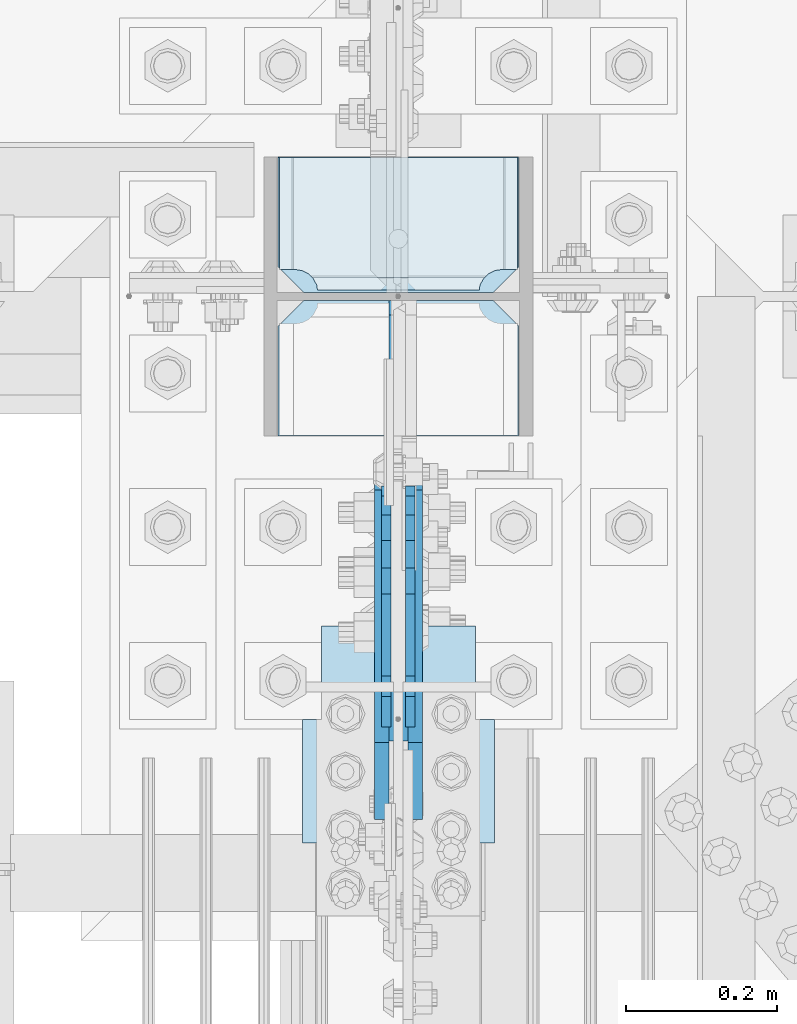
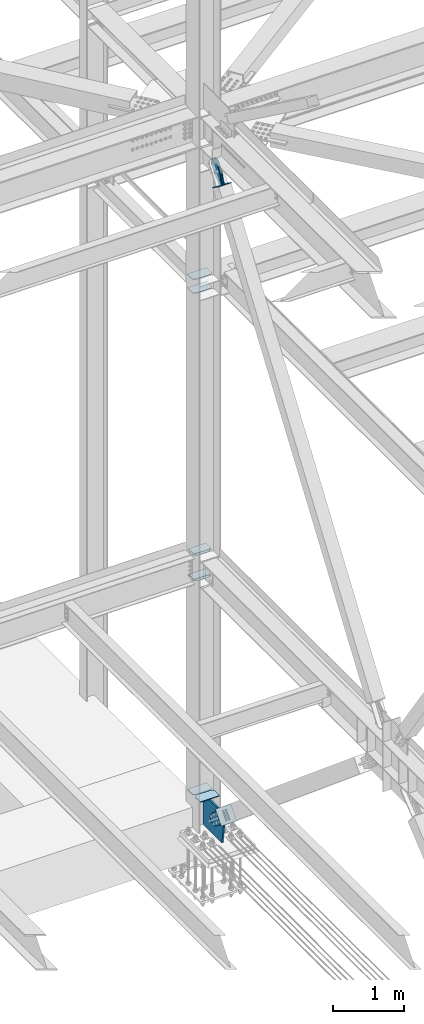
# One storey, part 3198 of 3843: 13 plates, 7 elements without a shape of their own.
"""IFC2X3 building model written with IfcOpenShell, lengths in millimetres."""

from ifc_helpers import new_model, si_unit, frame, origin_with_axes, place, context, subcontext, project, spatial, faceted_brep, material, type_object, element, aggregate, save


model = new_model("IFC2X3")

# Units and contexts
model_context = context("Model", 3, precision=1e-05, world=origin_with_axes())
body_context = subcontext(model_context, "Body", "Model", "MODEL_VIEW")
ifc_project = project(units=[si_unit("LENGTHUNIT", "METRE", prefix="MILLI"), si_unit("AREAUNIT", "SQUARE_METRE"), si_unit("VOLUMEUNIT", "CUBIC_METRE"), si_unit("MASSUNIT", "GRAM", prefix="KILO"), si_unit("TIMEUNIT", "SECOND"), si_unit("PLANEANGLEUNIT", "RADIAN"), si_unit("SOLIDANGLEUNIT", "STERADIAN"), si_unit("THERMODYNAMICTEMPERATUREUNIT", "DEGREE_CELSIUS"), si_unit("LUMINOUSINTENSITYUNIT", "LUMEN")], contexts=[model_context])

# Site, building, storey
site_placement = place(None, origin_with_axes())
site = spatial("IfcSite", under=ifc_project, at=site_placement, CompositionType="ELEMENT")
building_placement = place(site_placement, origin_with_axes())
building = spatial("IfcBuilding", under=site, at=building_placement, Name="Undefined", CompositionType="ELEMENT")
storey_placement = place(building_placement, origin_with_axes())
storey = spatial("IfcBuildingStorey", under=building, at=storey_placement, Name="Undefined", CompositionType="ELEMENT", Elevation=0.0)

# Assembly, plates
assembly_1_placement = place(storey_placement, origin_with_axes())
assembly_1 = element("IfcElementAssembly", 1, at=assembly_1_placement, inside=storey, Name="COLUMN", AssemblyPlace="NOTDEFINED", PredefinedType="RIGID_FRAME")
ifc_material_1 = material(Name="STEEL/A572-50")
plate_type_1 = type_object("IfcPlateType", PredefinedType="NOTDEFINED")
plate_1_placement = place(assembly_1_placement, frame((77171.55, 25799.25625, 39308.0875), z_axis=(-1.0, 0.0, 0.0), x_axis=(0.0, -1.0, 0.0)))
plate_1 = element("IfcPlate", 2, at=plate_1_placement, type_object=plate_type_1, material=ifc_material_1, Name="PLATE", context=body_context, shape_type="Brep", body=[
    faceted_brep([(0.0, -4.76249999999709, 0.0), (0.0, -4.76249999785796, 317.500000005042), (0.0, 4.76250000210712, 317.50000000505), (0.0, 4.76249999999709, 0.0), (144.462501525879, -4.76249999999709, 317.5), (144.462501525879, 4.76249999999709, 317.5), (177.800003051758, -4.76249999999709, 284.162498474121), (177.800003051758, 4.76249999999709, 284.162498474121), (177.800003051758, -4.76249999999709, 33.3375015258789), (177.800003051758, 4.76249999999709, 33.3375015258789), (144.462501525879, -4.76249999999709, 0.0), (144.462501525879, 4.76249999999709, 0.0)], [[[0, 1, 2, 3]], [[1, 4, 5, 2]], [[4, 6, 7, 5]], [[6, 8, 9, 7]], [[8, 10, 11, 9]], [[10, 0, 3, 11]], [[5, 7, 9, 11, 3, 2]], [[10, 8, 6, 4, 1, 0]]]),
])
plate_2_placement = place(assembly_1_placement, frame((77171.55, 25799.25625, 39546.2125), z_axis=(-1.0, 0.0, 0.0), x_axis=(0.0, -1.0, 0.0)))
plate_2 = element("IfcPlate", 3, at=plate_2_placement, type_object=plate_type_1, material=ifc_material_1, Name="PLATE", context=body_context, shape_type="Brep", body=[
    faceted_brep([(0.0, -4.76249999999709, 0.0), (0.0, -4.76249999785796, 317.500000005042), (0.0, 4.76250000210712, 317.50000000505), (0.0, 4.76249999999709, 0.0), (144.462501525879, -4.76249999999709, 317.5), (144.462501525879, 4.76249999999709, 317.5), (177.800003051758, -4.76249999999709, 284.162498474121), (177.800003051758, 4.76249999999709, 284.162498474121), (177.800003051758, -4.76249999999709, 33.3375015258789), (177.800003051758, 4.76249999999709, 33.3375015258789), (144.462501525879, -4.76249999999709, 0.0), (144.462501525879, 4.76249999999709, 0.0)], [[[0, 1, 2, 3]], [[1, 4, 5, 2]], [[4, 6, 7, 5]], [[6, 8, 9, 7]], [[8, 10, 11, 9]], [[10, 0, 3, 11]], [[5, 7, 9, 11, 3, 2]], [[10, 8, 6, 4, 1, 0]]]),
])
plate_type_2 = type_object("IfcPlateType", PredefinedType="NOTDEFINED")
plate_3_placement = place(assembly_1_placement, frame((77171.55, 25621.45625, 30670.8882042879), z_axis=(0.0, 1.0, 0.0), x_axis=(-1.0, 0.0, 0.0)))
plate_3 = element("IfcPlate", 4, at=plate_3_placement, type_object=plate_type_2, material=ifc_material_1, Name="CB_COL", context=body_context, shape_type="Brep", body=[
    faceted_brep([(0.0, -6.34999999999854, 33.3375015258789), (0.0, -6.34999999999854, 178.59375), (0.0, 6.34999999999854, 178.59375), (0.0, 6.34999999999854, 33.3375015258789), (317.499999999985, -6.34999999999854, 178.59375), (317.499999999985, 6.34999999999854, 178.59375), (317.499999999985, -6.34999999999854, 33.3375015258789), (317.499999999985, 6.34999999999854, 33.3375015258789), (284.162498474107, -6.34999999999854, 0.0), (284.162498474107, 6.34999999999854, 0.0), (33.3375015258789, -6.34999999999854, 0.0), (33.3375015258789, 6.34999999999854, 0.0)], [[[0, 1, 2, 3]], [[1, 4, 5, 2]], [[4, 6, 7, 5]], [[6, 8, 9, 7]], [[8, 10, 11, 9]], [[10, 0, 3, 11]], [[5, 7, 9, 11, 3, 2]], [[10, 8, 6, 4, 1, 0]]]),
])
plate_4_placement = place(assembly_1_placement, frame((77171.55, 25610.34375, 30670.8882042879), z_axis=(0.0, -1.0, 0.0), x_axis=(-1.0, 0.0, 0.0)))
plate_4 = element("IfcPlate", 5, at=plate_4_placement, type_object=plate_type_2, material=ifc_material_1, Name="CB_COL", context=body_context, shape_type="Brep", body=[
    faceted_brep([(0.0, -6.34999999999854, 33.3375015258789), (0.0, -6.34999999999854, 178.59375), (0.0, 6.34999999999854, 178.59375), (0.0, 6.34999999999854, 33.3375015258789), (317.499999999985, -6.34999999999854, 178.59375), (317.499999999985, 6.34999999999854, 178.59375), (317.499999999985, -6.34999999999854, 33.3375015258789), (317.499999999985, 6.34999999999854, 33.3375015258789), (284.162498474107, -6.34999999999854, 0.0), (284.162498474107, 6.34999999999854, 0.0), (33.3375015258789, -6.34999999999854, 0.0), (33.3375015258789, 6.34999999999854, 0.0)], [[[0, 1, 2, 3]], [[1, 4, 5, 2]], [[4, 6, 7, 5]], [[6, 8, 9, 7]], [[8, 10, 11, 9]], [[10, 0, 3, 11]], [[5, 7, 9, 11, 3, 2]], [[10, 8, 6, 4, 1, 0]]]),
])
plate_type_3 = type_object("IfcPlateType", PredefinedType="NOTDEFINED")
plate_5_placement = place(assembly_1_placement, frame((76852.4625, 25621.45625, 34358.2625), z_axis=(1.0, 0.0, 0.0), x_axis=(0.0, 1.0, 0.0)))
plate_5 = element("IfcPlate", 6, at=plate_5_placement, type_object=plate_type_3, material=ifc_material_1, Name="PLATE", context=body_context, shape_type="Brep", body=[
    faceted_brep([(17.7290728964945, 10.9213260443648, 272.460526505907), (19.6725343343096, 14.2874999999985, 274.403987943719), (19.6725343343096, 14.2874999999985, 46.2710120562842), (17.7290728964945, 10.9213260443648, 48.2144734940957), (9.32072521071677, -3.64235936715704, 52.4987406282016), (3.17474995173325, -14.2874999999985, 53.4721674798493), (3.17474995173325, -14.2874999999985, 267.202832520154), (9.32072521071314, -3.64235936715704, 268.176259371801), (30.1625003814697, 14.2874999999985, 301.002715665105), (30.1625003814697, -14.2874999999985, 317.500500047681), (177.799999999999, -14.2874999999985, 317.500500047681), (177.799999999999, 14.2874999999985, 301.002715665105), (177.799999999999, 14.2874999999985, 19.672284334898), (177.799999999999, -14.2874999999985, 3.17449995232164), (30.1625003814697, -14.2874999999985, 3.17449995232164), (30.1625003814697, 14.2874999999985, 19.672284334898), (9.32072521071314, -14.2874999999985, 268.176259371801), (17.7290728964945, -14.2874999999985, 272.460526505907), (24.401975401448, -14.2874999999985, 279.133429010864), (24.401975401448, 14.2874999999985, 279.133429010864), (28.6862425355503, -14.2874999999985, 287.541776696642), (28.6862425355503, 14.2874999999985, 287.541776696642), (30.1625003814697, -14.2874999999985, 296.862501907352), (30.1625003814697, 14.2874999999985, 296.862501907352), (30.1625003814697, -14.2874999999985, 23.8124980926514), (30.1625003814697, 14.2874999999985, 23.8124980926514), (28.6862425355503, -14.2874999999985, 33.1332233033609), (28.6862425355503, 14.2874999999985, 33.1332233033609), (24.401975401448, -14.2874999999985, 41.5415709891386), (24.401975401448, 14.2874999999985, 41.5415709891386), (17.7290728964945, -14.2874999999985, 48.2144734940957), (9.32072521071677, -14.2874999999985, 52.4987406282016)], [[[0, 1, 2, 3, 4, 5, 6, 7]], [[8, 9, 10, 11]], [[12, 13, 14, 15]], [[16, 7, 6]], [[16, 17, 0, 7]], [[17, 18, 19, 1, 0]], [[18, 20, 21, 19]], [[20, 22, 23, 21]], [[23, 22, 9, 8]], [[13, 12, 11, 10]], [[24, 25, 15, 14]], [[24, 26, 27, 25]], [[26, 28, 29, 27]], [[29, 28, 30, 3, 2]], [[30, 31, 4, 3]], [[31, 5, 4]], [[19, 21, 23, 8, 11, 12, 15, 25, 27, 29, 2, 1]], [[31, 30, 28, 26, 24, 14, 13, 10, 9, 22, 20, 18, 17, 16, 6, 5]]]),
])
plate_6_placement = place(assembly_1_placement, frame((76852.4625, 25621.45625, 34796.4125), z_axis=(1.0, 0.0, 0.0), x_axis=(0.0, 1.0, 0.0)))
plate_6 = element("IfcPlate", 7, at=plate_6_placement, type_object=plate_type_3, material=ifc_material_1, Name="PLATE", context=body_context, shape_type="Brep", body=[
    faceted_brep([(17.7290728964945, 10.9213260443648, 272.460526505907), (19.6725343343096, 14.2874999999985, 274.403987943719), (19.6725343343096, 14.2874999999985, 46.2710120562842), (17.7290728964945, 10.9213260443648, 48.2144734940957), (9.32072521071677, -3.64235936715704, 52.4987406282016), (3.17474995173325, -14.2874999999985, 53.4721674798493), (3.17474995173325, -14.2874999999985, 267.202832520154), (9.32072521071314, -3.64235936715704, 268.176259371801), (30.1625003814697, 14.2874999999985, 301.002715665105), (30.1625003814697, -14.2874999999985, 317.500500047681), (177.799999999999, -14.2874999999985, 317.500500047681), (177.799999999999, 14.2874999999985, 301.002715665105), (177.799999999999, 14.2874999999985, 19.672284334898), (177.799999999999, -14.2874999999985, 3.17449995232164), (30.1625003814697, -14.2874999999985, 3.17449995232164), (30.1625003814697, 14.2874999999985, 19.672284334898), (9.32072521071314, -14.2874999999985, 268.176259371801), (17.7290728964945, -14.2874999999985, 272.460526505907), (24.401975401448, -14.2874999999985, 279.133429010864), (24.401975401448, 14.2874999999985, 279.133429010864), (28.6862425355503, -14.2874999999985, 287.541776696642), (28.6862425355503, 14.2874999999985, 287.541776696642), (30.1625003814697, -14.2874999999985, 296.862501907352), (30.1625003814697, 14.2874999999985, 296.862501907352), (30.1625003814697, -14.2874999999985, 23.8124980926514), (30.1625003814697, 14.2874999999985, 23.8124980926514), (28.6862425355503, -14.2874999999985, 33.1332233033609), (28.6862425355503, 14.2874999999985, 33.1332233033609), (24.401975401448, -14.2874999999985, 41.5415709891386), (24.401975401448, 14.2874999999985, 41.5415709891386), (17.7290728964945, -14.2874999999985, 48.2144734940957), (9.32072521071677, -14.2874999999985, 52.4987406282016)], [[[0, 1, 2, 3, 4, 5, 6, 7]], [[8, 9, 10, 11]], [[12, 13, 14, 15]], [[16, 7, 6]], [[16, 17, 0, 7]], [[17, 18, 19, 1, 0]], [[18, 20, 21, 19]], [[20, 22, 23, 21]], [[23, 22, 9, 8]], [[13, 12, 11, 10]], [[24, 25, 15, 14]], [[24, 26, 27, 25]], [[26, 28, 29, 27]], [[29, 28, 30, 3, 2]], [[30, 31, 4, 3]], [[31, 5, 4]], [[19, 21, 23, 8, 11, 12, 15, 25, 27, 29, 2, 1]], [[31, 30, 28, 26, 24, 14, 13, 10, 9, 22, 20, 18, 17, 16, 6, 5]]]),
])

# Assembly, plate
assembly_2_placement = place(storey_placement, origin_with_axes())
assembly_2 = element("IfcElementAssembly", 8, at=assembly_2_placement, inside=storey, Name="Plate", AssemblyPlace="NOTDEFINED", PredefinedType="RIGID_FRAME")
ifc_material_2 = material(Name="STEEL/A36")
plate_type_4 = type_object("IfcPlateType", PredefinedType="NOTDEFINED")
plate_7_placement = place(assembly_2_placement, frame((77114.4, 25178.3977542612, 41391.6050428605), z_axis=(0.0, -0.820514786824001, 0.571625300877388), x_axis=(-1.0, 0.0, 0.0)))
plate_7 = element("IfcPlate", 9, at=plate_7_placement, type_object=plate_type_4, material=ifc_material_2, Name="Plate", context=body_context, shape_type="Brep", body=[
    faceted_brep([(0.0, -3.17499999999927, 0.0), (0.0, -3.17500000043947, 203.200000001736), (0.0, 3.1749999995518, 203.200000001743), (0.0, 3.17499999999927, 0.0), (203.200000000012, -3.17500000043947, 203.200000001736), (203.200000000012, 3.1749999995518, 203.200000001743), (203.199996948242, -3.17499999999927, 0.0), (203.199996948242, 3.17499999999927, 0.0)], [[[0, 1, 2, 3]], [[1, 4, 5, 2]], [[4, 6, 7, 5]], [[6, 0, 3, 7]], [[5, 7, 3, 2]], [[6, 4, 1, 0]]]),
])
aggregate(assembly_2, [plate_7])

assembly_3_placement = place(storey_placement, origin_with_axes())
assembly_3 = element("IfcElementAssembly", 10, at=assembly_3_placement, inside=storey, AssemblyPlace="NOTDEFINED", PredefinedType="RIGID_FRAME")
plate_type_5 = type_object("IfcPlateType", PredefinedType="NOTDEFINED")
plate_8_placement = place(assembly_3_placement, frame((76990.575, 25026.2019430032, 30733.5856528304), z_axis=(0.0, -0.641582193978324, -0.767054292974077), x_axis=(0.0, 0.767054292974076, -0.641582193978324)))
plate_8 = element("IfcPlate", 11, at=plate_8_placement, type_object=plate_type_5, material=ifc_material_2, context=body_context, shape_type="Brep", body=[
    faceted_brep([(0.0, -9.52500000000146, 0.0), (1.71894498635083e-09, -9.52499999999418, 158.39421297863), (1.71894498635083e-09, 9.52499999999418, 158.39421297863), (0.0, 9.52500000000146, 0.0), (69.8500000010408, -9.52499999999418, 158.394212979103), (69.8500000010408, 9.52499999999418, 158.394212979103), (171.450000002631, -9.52499999999418, 176.034606488582), (171.450000002631, 9.52499999999418, 176.034606488582), (390.129297671807, -9.52499999999418, 176.034606487716), (390.129297671807, 9.52499999999418, 176.034606487716), (427.187405137312, -9.52499999999418, 168.663290600991), (427.187405137312, 9.52499999999418, 168.663290600991), (458.60375167372, -9.52499999999418, 147.671558963724), (458.60375167372, 9.52499999999418, 147.671558963724), (479.59548331075, -9.52499999999418, 116.255212427161), (479.59548331075, 9.52499999999418, 116.255212427161), (486.966799197198, -9.52499999999418, 79.1971080138683), (486.966799197198, 9.52499999999418, 79.1971080138683), (479.595483310488, -9.52499999999418, 42.1390005483336), (479.595483310488, 9.52499999999418, 42.1390005483336), (458.603751673207, -9.52499999999418, 10.7226540119082), (458.603751673207, 9.52499999999418, 10.7226540119082), (427.18740513661, -9.52499999999418, -10.2690776251402), (427.18740513661, 9.52499999999418, -10.2690776251402), (390.129299195723, -9.52499999999418, -17.6403935115741), (390.129299195723, 9.52499999999418, -17.6403935115741), (171.450000001962, -9.52499999999418, -17.6403935107155), (171.450000001962, 9.52499999999418, -17.6403935107155), (69.8499999979995, -9.52499999999418, -4.00177668780088e-10), (69.8499999979995, 9.52499999999418, -4.00177668780088e-10)], [[[0, 1, 2, 3]], [[1, 4, 5, 2]], [[4, 6, 7, 5]], [[6, 8, 9, 7]], [[8, 10, 11, 9]], [[10, 12, 13, 11]], [[12, 14, 15, 13]], [[14, 16, 17, 15]], [[16, 18, 19, 17]], [[18, 20, 21, 19]], [[20, 22, 23, 21]], [[22, 24, 25, 23]], [[24, 26, 27, 25]], [[26, 28, 29, 27]], [[28, 0, 3, 29]], [[5, 7, 9, 11, 13, 15, 17, 19, 21, 23, 25, 27, 29, 3, 2]], [[28, 26, 24, 22, 20, 18, 16, 14, 12, 10, 8, 6, 4, 1, 0]]]),
])
aggregate(assembly_3, [plate_8])

assembly_4_placement = place(storey_placement, origin_with_axes())
assembly_4 = element("IfcElementAssembly", 12, at=assembly_4_placement, inside=storey, AssemblyPlace="NOTDEFINED", PredefinedType="RIGID_FRAME")
plate_9_placement = place(assembly_4_placement, frame((77035.025, 25026.2019430032, 30733.5856528304), z_axis=(0.0, -0.641582193978324, -0.767054292974077), x_axis=(0.0, 0.767054292974076, -0.641582193978324)))
plate_9 = element("IfcPlate", 13, at=plate_9_placement, type_object=plate_type_5, material=ifc_material_2, context=body_context, shape_type="Brep", body=[
    faceted_brep([(0.0, -9.52500000000146, 0.0), (1.71894498635083e-09, -9.52499999999418, 158.39421297863), (1.71894498635083e-09, 9.52499999999418, 158.39421297863), (0.0, 9.52500000000146, 0.0), (69.8500000010408, -9.52499999999418, 158.394212979103), (69.8500000010408, 9.52499999999418, 158.394212979103), (171.450000002631, -9.52499999999418, 176.034606488582), (171.450000002631, 9.52499999999418, 176.034606488582), (390.129297671807, -9.52499999999418, 176.034606487716), (390.129297671807, 9.52499999999418, 176.034606487716), (427.187405137312, -9.52499999999418, 168.663290600991), (427.187405137312, 9.52499999999418, 168.663290600991), (458.60375167372, -9.52499999999418, 147.671558963724), (458.60375167372, 9.52499999999418, 147.671558963724), (479.59548331075, -9.52499999999418, 116.255212427161), (479.59548331075, 9.52499999999418, 116.255212427161), (486.966799197198, -9.52499999999418, 79.1971080138683), (486.966799197198, 9.52499999999418, 79.1971080138683), (479.595483310488, -9.52499999999418, 42.1390005483336), (479.595483310488, 9.52499999999418, 42.1390005483336), (458.603751673207, -9.52499999999418, 10.7226540119082), (458.603751673207, 9.52499999999418, 10.7226540119082), (427.18740513661, -9.52499999999418, -10.2690776251402), (427.18740513661, 9.52499999999418, -10.2690776251402), (390.129299195723, -9.52499999999418, -17.6403935115741), (390.129299195723, 9.52499999999418, -17.6403935115741), (171.450000001962, -9.52499999999418, -17.6403935107155), (171.450000001962, 9.52499999999418, -17.6403935107155), (69.8499999979995, -9.52499999999418, -4.00177668780088e-10), (69.8499999979995, 9.52499999999418, -4.00177668780088e-10)], [[[0, 1, 2, 3]], [[1, 4, 5, 2]], [[4, 6, 7, 5]], [[6, 8, 9, 7]], [[8, 10, 11, 9]], [[10, 12, 13, 11]], [[12, 14, 15, 13]], [[14, 16, 17, 15]], [[16, 18, 19, 17]], [[18, 20, 21, 19]], [[20, 22, 23, 21]], [[22, 24, 25, 23]], [[24, 26, 27, 25]], [[26, 28, 29, 27]], [[28, 0, 3, 29]], [[5, 7, 9, 11, 13, 15, 17, 19, 21, 23, 25, 27, 29, 3, 2]], [[28, 26, 24, 22, 20, 18, 16, 14, 12, 10, 8, 6, 4, 1, 0]]]),
])
aggregate(assembly_4, [plate_9])

assembly_5_placement = place(storey_placement, origin_with_axes())
assembly_5 = element("IfcElementAssembly", 14, at=assembly_5_placement, inside=storey, Name="Plate", AssemblyPlace="NOTDEFINED", PredefinedType="RIGID_FRAME")
plate_type_6 = type_object("IfcPlateType", PredefinedType="NOTDEFINED")
plate_10_placement = place(assembly_5_placement, frame((76885.8, 24896.3449484357, 30573.384253661), z_axis=(0.0, 0.641582193978324, 0.767054292974077), x_axis=(1.0, 0.0, 0.0)))
plate_10 = element("IfcPlate", 15, at=plate_10_placement, type_object=plate_type_6, material=ifc_material_2, Name="Plate", context=body_context, shape_type="Brep", body=[
    faceted_brep([(0.0, -3.17499999999927, 0.0), (0.0, -3.17499999965185, 254.000000005151), (0.0, 3.17500000035216, 254.000000005166), (0.0, 3.17499999999927, 0.0), (254.0, -3.17499999965185, 254.000000005151), (254.0, 3.17500000035216, 254.000000005166), (254.0, -3.17500000000291, 0.0), (254.0, 3.17499999999927, 1.45519152283669e-11)], [[[0, 1, 2, 3]], [[1, 4, 5, 2]], [[4, 6, 7, 5]], [[6, 0, 3, 7]], [[5, 7, 3, 2]], [[6, 4, 1, 0]]]),
])
aggregate(assembly_5, [plate_10])

assembly_6_placement = place(storey_placement, origin_with_axes())
assembly_6 = element("IfcElementAssembly", 16, at=assembly_6_placement, inside=storey, AssemblyPlace="NOTDEFINED", PredefinedType="RIGID_FRAME")
plate_type_7 = type_object("IfcPlateType", PredefinedType="NOTDEFINED")
plate_11_placement = place(assembly_6_placement, frame((76996.925, 25139.2432385791, 41415.0131667273), z_axis=(0.0, -0.820514786824001, 0.571625300877388), x_axis=(0.0, 0.571625300877386, 0.820514786824002)))
plate_11 = element("IfcPlate", 17, at=plate_11_placement, type_object=plate_type_7, material=ifc_material_2, context=body_context, shape_type="Brep", body=[
    faceted_brep([(0.0, -6.3499999046162, 0.0), (4.9622030928731e-09, -6.35000000000582, 112.184930798256), (4.9622030928731e-09, 6.35000000000582, 112.184930798256), (7.27595761418343e-12, 6.3499999046162, 0.0), (69.8500000038475, -6.35000000000582, 112.184930798168), (69.8500000038475, 6.35000000000582, 112.184930798168), (171.450000003882, -6.35000000000582, 149.754965398664), (171.450000003882, 6.35000000000582, 149.754965398664), (315.219242329083, -6.35000000000582, 149.754965398519), (315.219242329083, 6.35000000000582, 149.754965398519), (351.06232873004, -6.35000000000582, 142.625332228003), (351.06232873004, 6.35000000000582, 142.625332228003), (381.448630144558, -6.35000000000582, 122.321854736569), (381.448630144558, 6.35000000000582, 122.321854736569), (401.752107634529, -6.35000000000582, 91.9355533209819), (401.752107634529, 6.35000000000582, 91.9355533209819), (408.881740803365, -6.35000000000582, 56.0924638688084), (408.881740803365, 6.35000000000582, 56.0924638688084), (401.75210763223, -6.35000000000582, 20.2493774701215), (401.75210763223, 6.35000000000582, 20.2493774701215), (381.448630141909, -6.35000000000582, -10.1369239423584), (381.448630141909, 6.35000000000582, -10.1369239423584), (351.062328728673, -6.35000000000582, -30.4404014313986), (351.062328728673, 6.35000000000582, -30.4404014313986), (315.219240800725, -6.35000000000582, -37.5700346009617), (315.219240800725, 6.35000000000582, -37.5700346009617), (171.449999995632, -6.35000000000582, -37.5700346008307), (171.449999995632, 6.35000000000582, -37.5700346008307), (69.8499999985434, -6.35000000000582, -8.73114913702011e-11), (69.8499999985434, 6.35000000000582, -8.73114913702011e-11)], [[[0, 1, 2, 3]], [[1, 4, 5, 2]], [[4, 6, 7, 5]], [[6, 8, 9, 7]], [[8, 10, 11, 9]], [[10, 12, 13, 11]], [[12, 14, 15, 13]], [[14, 16, 17, 15]], [[16, 18, 19, 17]], [[18, 20, 21, 19]], [[20, 22, 23, 21]], [[22, 24, 25, 23]], [[24, 26, 27, 25]], [[26, 28, 29, 27]], [[28, 0, 3, 29]], [[5, 7, 9, 11, 13, 15, 17, 19, 21, 23, 25, 27, 29, 3, 2]], [[28, 26, 24, 22, 20, 18, 16, 14, 12, 10, 8, 6, 4, 1, 0]]]),
])
aggregate(assembly_6, [plate_11])

assembly_7_placement = place(storey_placement, origin_with_axes())
assembly_7 = element("IfcElementAssembly", 18, at=assembly_7_placement, inside=storey, AssemblyPlace="NOTDEFINED", PredefinedType="RIGID_FRAME")
plate_12_placement = place(assembly_7_placement, frame((77028.675, 25139.2432385791, 41415.0131667273), z_axis=(0.0, -0.820514786824001, 0.571625300877388), x_axis=(0.0, 0.571625300877386, 0.820514786824002)))
plate_12 = element("IfcPlate", 19, at=plate_12_placement, type_object=plate_type_7, material=ifc_material_2, context=body_context, shape_type="Brep", body=[
    faceted_brep([(0.0, -6.3499999046162, 0.0), (4.9622030928731e-09, -6.35000000000582, 112.184930798256), (4.9622030928731e-09, 6.35000000000582, 112.184930798256), (7.27595761418343e-12, 6.3499999046162, 0.0), (69.8500000038475, -6.35000000000582, 112.184930798168), (69.8500000038475, 6.35000000000582, 112.184930798168), (171.450000003882, -6.35000000000582, 149.754965398664), (171.450000003882, 6.35000000000582, 149.754965398664), (315.219242329083, -6.35000000000582, 149.754965398519), (315.219242329083, 6.35000000000582, 149.754965398519), (351.06232873004, -6.35000000000582, 142.625332228003), (351.06232873004, 6.35000000000582, 142.625332228003), (381.448630144558, -6.35000000000582, 122.321854736569), (381.448630144558, 6.35000000000582, 122.321854736569), (401.752107634529, -6.35000000000582, 91.9355533209819), (401.752107634529, 6.35000000000582, 91.9355533209819), (408.881740803365, -6.35000000000582, 56.0924638688084), (408.881740803365, 6.35000000000582, 56.0924638688084), (401.75210763223, -6.35000000000582, 20.2493774701215), (401.75210763223, 6.35000000000582, 20.2493774701215), (381.448630141909, -6.35000000000582, -10.1369239423584), (381.448630141909, 6.35000000000582, -10.1369239423584), (351.062328728673, -6.35000000000582, -30.4404014313986), (351.062328728673, 6.35000000000582, -30.4404014313986), (315.219240800725, -6.35000000000582, -37.5700346009617), (315.219240800725, 6.35000000000582, -37.5700346009617), (171.449999995632, -6.35000000000582, -37.5700346008307), (171.449999995632, 6.35000000000582, -37.5700346008307), (69.8499999985434, -6.35000000000582, -8.73114913702011e-11), (69.8499999985434, 6.35000000000582, -8.73114913702011e-11)], [[[0, 1, 2, 3]], [[1, 4, 5, 2]], [[4, 6, 7, 5]], [[6, 8, 9, 7]], [[8, 10, 11, 9]], [[10, 12, 13, 11]], [[12, 14, 15, 13]], [[14, 16, 17, 15]], [[16, 18, 19, 17]], [[18, 20, 21, 19]], [[20, 22, 23, 21]], [[22, 24, 25, 23]], [[24, 26, 27, 25]], [[26, 28, 29, 27]], [[28, 0, 3, 29]], [[5, 7, 9, 11, 13, 15, 17, 19, 21, 23, 25, 27, 29, 3, 2]], [[28, 26, 24, 22, 20, 18, 16, 14, 12, 10, 8, 6, 4, 1, 0]]]),
])
aggregate(assembly_7, [plate_12])

# Plate
plate_type_8 = type_object("IfcPlateType", PredefinedType="NOTDEFINED")
plate_13_placement = place(assembly_1_placement, frame((77012.8, 25610.34375, 30137.1), z_axis=(0.0, 0.0, 1.0), x_axis=(0.0, -1.0, 0.0)))
plate_13 = element("IfcPlate", 20, at=plate_13_placement, type_object=plate_type_8, material=ifc_material_1, Name="CB", context=body_context, shape_type="Brep", body=[
    faceted_brep([(0.0, -12.6999999999971, 19.0499992370605), (0.0, -12.6999999999971, 508.388205050873), (0.0, 12.6999999999971, 508.388205050873), (0.0, 12.6999999999971, 19.0499992370605), (19.0499992370605, -12.6999999999971, 527.438204287933), (19.0499992370605, 12.6999999999971, 527.438204287933), (418.377287277006, -12.6999999999971, 527.438204287933), (418.377287277006, 12.6999999999971, 527.438204287933), (581.867205243161, -12.6999999999971, 331.975106013095), (581.867205243161, 12.6999999999971, 331.975106013095), (533.399999999998, -12.6999999999971, 0.0), (533.399999999998, 12.6999999999971, 0.0), (19.0500015258731, -12.6999999999971, -6.33008312433958e-10), (19.0500015258731, 12.6999999999971, 0.0)], [[[0, 1, 2, 3]], [[1, 4, 5, 2]], [[4, 6, 7, 5]], [[6, 8, 9, 7]], [[8, 10, 11, 9]], [[10, 12, 13, 11]], [[12, 0, 3, 13]], [[5, 7, 9, 11, 13, 3, 2]], [[12, 10, 8, 6, 4, 1, 0]]]),
])

aggregate(assembly_1, [plate_5, plate_6, plate_3, plate_4, plate_13, plate_1, plate_2])

save(model, "model.ifc")
